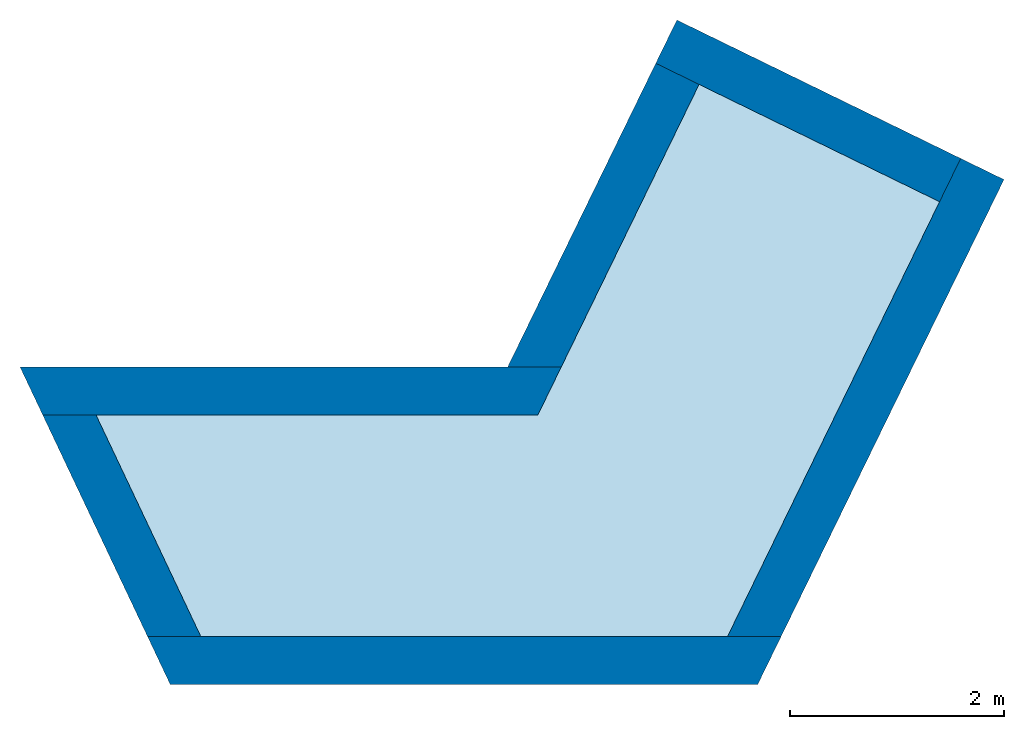
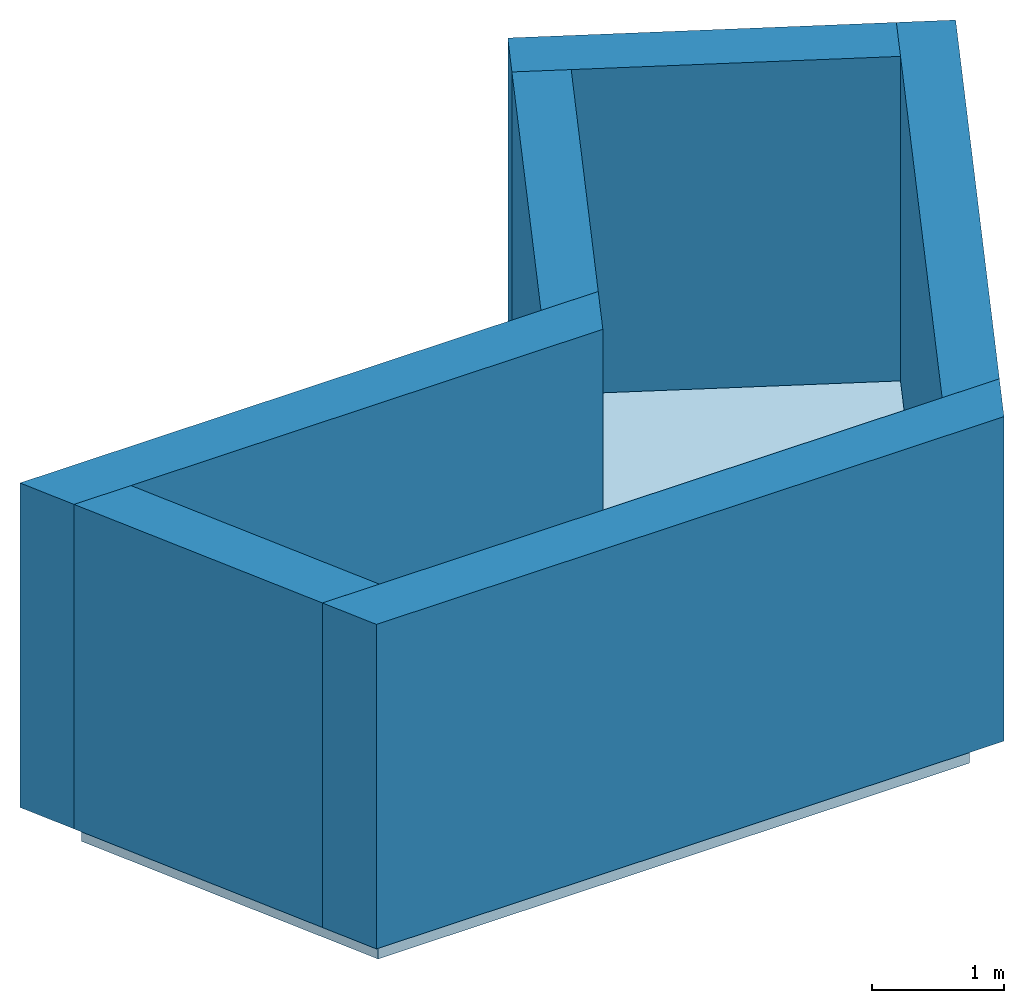
# One storey: 6 walls, 1 slab, 1 opening.
"""IFC4 building model written with IfcOpenShell, lengths in metres."""

import ifcopenshell
import ifcopenshell.guid

model = None  # the IFC model being written
_history = None  # IfcOwnerHistory: only IFC2X3 demands one
_inside = {}  # id of a spatial element -> (the spatial element, [elements in it])
_under = {}  # id of a project, library or spatial element -> (it, [spatial elements below it])
_declared = {}  # id of a project -> (the project, [libraries it declares])
_typed = {}  # id of a type object -> (the type object, [elements of that type])
_made_of = {}  # id of a material, layer set ... -> (it, [elements and type objects made of it])


def new_model(schema):
    """Start an empty IFC model of exactly this schema.

    Asked for "IFC4X3", IfcOpenShell would pick the latest addendum, in which some entities
    have other attributes; the version numbers below select the first issue.
    IFC2X3 requires an IfcOwnerHistory on every rooted entity: one is made here for all.
    """
    global model, _history
    if schema == "IFC4X3":
        model = ifcopenshell.file(schema_version=(4, 3, 0, 0))
    else:
        model = ifcopenshell.file(schema=schema)
    _inside.clear()
    _under.clear()
    _declared.clear()
    _typed.clear()
    _made_of.clear()
    _history = None
    if model.schema == "IFC2X3":
        org = make("IfcOrganization", Name="unknown")
        user = make(
            "IfcPersonAndOrganization",
            ThePerson=make("IfcPerson", FamilyName="unknown"),
            TheOrganization=org,
        )
        app = make(
            "IfcApplication",
            ApplicationDeveloper=org,
            Version="unknown",
            ApplicationFullName="unknown",
            ApplicationIdentifier="unknown",
        )
        _history = make(
            "IfcOwnerHistory",
            OwningUser=user,
            OwningApplication=app,
            ChangeAction="ADDED",
            CreationDate=0,
        )
    return model


def make(cls, **values):
    """One entity of the class cls with the attributes given. An attribute that is None is left unset."""
    return model.create_entity(
        cls, **{name: value for name, value in values.items() if value is not None}
    )


def entity(cls, *values):
    """Any entity or typed value of the class cls, its attributes in the order of the schema. None: left unset."""
    e = model.create_entity(cls)
    for i, value in enumerate(values):
        if value is not None:
            e[i] = value
    return e


def rooted(cls, **values):
    """An entity with a GlobalId (a new one), such as an element, a storey or a relation."""
    return make(cls, GlobalId=ifcopenshell.guid.new(), OwnerHistory=_history, **values)


def si_unit(unit_type, name, prefix=None):
    """IfcSIUnit, for example si_unit("LENGTHUNIT", "METRE", prefix="MILLI")."""
    return make("IfcSIUnit", UnitType=unit_type, Prefix=prefix, Name=name)


def converted_unit(unit_type, name, factor, base, dimensions=None, offset=None):
    """IfcConversionBasedUnit, such as the inch: factor (a typed value) times the base unit."""
    return make(
        "IfcConversionBasedUnit"
        if offset is None
        else "IfcConversionBasedUnitWithOffset",
        ConversionOffset=offset,
        Dimensions=None
        if dimensions is None
        else entity("IfcDimensionalExponents", *dimensions),
        UnitType=unit_type,
        Name=name,
        ConversionFactor=make(
            "IfcMeasureWithUnit", ValueComponent=factor, UnitComponent=base
        ),
    )


def derived_unit(unit_type, elements):
    """IfcDerivedUnit: a product of units, each with its exponent."""
    return make(
        "IfcDerivedUnit",
        Elements=[
            make("IfcDerivedUnitElement", Unit=unit, Exponent=power)
            for unit, power in elements
        ],
        UnitType=unit_type,
    )


def assignment(units):
    """IfcUnitAssignment: the units of a project."""
    return None if units is None else make("IfcUnitAssignment", Units=units)


def point(xyz):
    """IfcCartesianPoint."""
    return None if xyz is None else make("IfcCartesianPoint", Coordinates=xyz)


def direction(xyz):
    """IfcDirection."""
    return None if xyz is None else make("IfcDirection", DirectionRatios=xyz)


def frame(location, z_axis=None, x_axis=None):
    """IfcAxis2Placement3D, a coordinate frame: its origin and axes. An axis left out is left unset."""
    return make(
        "IfcAxis2Placement3D",
        Location=point(location),
        Axis=direction(z_axis),
        RefDirection=direction(x_axis),
    )


def origin():
    """The frame at (0, 0, 0) with its axes left unset."""
    return frame((0.0, 0.0, 0.0))


def place(relative_to, where):
    """IfcLocalPlacement: puts the frame where relative to a parent placement (None: the world)."""
    return make(
        "IfcLocalPlacement", PlacementRelTo=relative_to, RelativePlacement=where
    )


def context(
    kind, dimensions, precision=None, world=None, true_north=None, identifier=None
):
    """IfcGeometricRepresentationContext, for example the 3D "Model" context."""
    return make(
        "IfcGeometricRepresentationContext",
        ContextIdentifier=identifier,
        ContextType=kind,
        CoordinateSpaceDimension=dimensions,
        Precision=precision,
        WorldCoordinateSystem=world,
        TrueNorth=true_north,
    )


def subcontext(parent, identifier, kind, view, scale=None):
    """IfcGeometricRepresentationSubContext, for example "Body" below "Model"."""
    return make(
        "IfcGeometricRepresentationSubContext",
        ContextIdentifier=identifier,
        ContextType=kind,
        ParentContext=parent,
        TargetScale=scale,
        TargetView=view,
    )


def project(units=None, contexts=None):
    """IfcProject with its units and contexts."""
    return rooted(
        "IfcProject",
        Name="project",
        RepresentationContexts=contexts,
        UnitsInContext=assignment(units),
    )


def spatial(cls, under=None, at=None, **own):
    """A site, building, storey or space (cls), placed at a placement, below another one or the project."""
    s = rooted(cls, ObjectPlacement=at, **own)
    if under is not None:
        _under.setdefault(under.id(), (under, []))[1].append(s)
    return s


def point_list(points):
    """IfcCartesianPointList2D or 3D."""
    cls = (
        "IfcCartesianPointList2D" if len(points[0]) == 2 else "IfcCartesianPointList3D"
    )
    return make(cls, CoordList=points)


def indexed_curve(points, segments=None, self_intersect=None):
    """IfcIndexedPolyCurve: lines and arcs through numbered points (the first is 1)."""
    return make(
        "IfcIndexedPolyCurve",
        Points=point_list(points),
        Segments=segments,
        SelfIntersect=self_intersect,
    )


def outline(outer, holes=None, kind="AREA"):
    """IfcArbitraryClosedProfileDef: a profile drawn as a closed curve; with holes, ...WithVoids."""
    if holes is None:
        return make("IfcArbitraryClosedProfileDef", ProfileType=kind, OuterCurve=outer)
    return make(
        "IfcArbitraryProfileDefWithVoids",
        ProfileType=kind,
        OuterCurve=outer,
        InnerCurves=holes,
    )


def extrude(swept, where, along, depth):
    """IfcExtrudedAreaSolid: the profile swept, set in the frame where, extruded along a direction by depth."""
    return make(
        "IfcExtrudedAreaSolid",
        SweptArea=swept,
        Position=where,
        ExtrudedDirection=direction(along),
        Depth=depth,
    )


def polygons(points, faces, closed=None, point_numbers=None):
    """IfcPolygonalFaceSet: a face is its outer loop, then its inner loops; points numbered from 1."""
    made = []
    for loops in faces:
        if len(loops) == 1:
            made.append(make("IfcIndexedPolygonalFace", CoordIndex=loops[0]))
        else:
            made.append(
                make(
                    "IfcIndexedPolygonalFaceWithVoids",
                    CoordIndex=loops[0],
                    InnerCoordIndices=loops[1:],
                )
            )
    return make(
        "IfcPolygonalFaceSet",
        Coordinates=point_list(points),
        Closed=closed,
        Faces=made,
        PnIndex=point_numbers,
    )


def shape(context_of_items, identifier, shape_type, items):
    """IfcShapeRepresentation: the items that make up one representation, for example the "Body"."""
    return make(
        "IfcShapeRepresentation",
        ContextOfItems=context_of_items,
        RepresentationIdentifier=identifier,
        RepresentationType=shape_type,
        Items=items,
    )


def material(Name=None, Category=None):
    """IfcMaterial."""
    return make("IfcMaterial", Name=Name, Category=Category)


def layer(
    of_material, thickness, ventilated=None, Name=None, Category=None, Priority=None
):
    """IfcMaterialLayer: one layer of a wall or slab, of a material (None: an air gap)."""
    return make(
        "IfcMaterialLayer",
        Material=of_material,
        LayerThickness=thickness,
        IsVentilated=ventilated,
        Name=Name,
        Category=Category,
        Priority=Priority,
    )


def layer_set(layers, Name=None):
    """IfcMaterialLayerSet."""
    return make("IfcMaterialLayerSet", MaterialLayers=layers, LayerSetName=Name)


def made_of(thing, what):
    """Note that an element or type object is made of a material, layer set ...; save() writes the relation."""
    if what is not None:
        _made_of.setdefault(what.id(), (what, []))[1].append(thing)
    return thing


def type_object(cls, material=None, **own):
    """A type object (cls), such as IfcWallType, which elements share."""
    return made_of(rooted(cls, **own), material)


def element(
    cls,
    number,
    at=None,
    inside=None,
    cuts=None,
    type_object=None,
    material=None,
    context=None,
    identifier="Body",
    shape_type=None,
    held_by="IfcProductDefinitionShape",
    body=None,
    shapes=None,
    **own,
):
    """One element of the class cls, such as IfcWall. Its Tag is "e" and its number.

    at: its placement. inside: the storey or other place that contains it. cuts: it is an
    opening in that element (IfcRelVoidsElement). A single representation is given by context,
    identifier, shape_type and body (its items); several are given by shapes. held_by: the class
    of the entity that holds the representations. save() writes the other relations.
    """
    e = rooted(cls, Tag="e%d" % number, ObjectPlacement=at, **own)
    if body is not None:
        shapes = [shape(context, identifier, shape_type, body)]
    if shapes is not None:
        e.Representation = make(held_by, Representations=shapes)
    if inside is not None:
        _inside.setdefault(inside.id(), (inside, []))[1].append(e)
    if cuts is not None:
        rooted(
            "IfcRelVoidsElement", RelatingBuildingElement=cuts, RelatedOpeningElement=e
        )
    if type_object is not None:
        _typed.setdefault(type_object.id(), (type_object, []))[1].append(e)
    return made_of(e, material)


def aggregate(whole, parts):
    """IfcRelAggregates: a whole, such as a stair, and the parts it consists of."""
    return rooted("IfcRelAggregates", RelatingObject=whole, RelatedObjects=parts)


def save(model, path):
    """Write the relations noted so far, then the file.

    IfcRelAggregates (storeys below a building ...), IfcRelContainedInSpatialStructure (elements
    in a storey), IfcRelDefinesByType, IfcRelAssociatesMaterial and IfcRelDeclares: one each for
    every whole, place, type object, material and project.
    """
    for whole, parts in _under.values():
        aggregate(whole, parts)
    for where, things in _inside.values():
        rooted(
            "IfcRelContainedInSpatialStructure",
            RelatedElements=things,
            RelatingStructure=where,
        )
    for kind, things in _typed.values():
        rooted("IfcRelDefinesByType", RelatedObjects=things, RelatingType=kind)
    for what, things in _made_of.values():
        rooted("IfcRelAssociatesMaterial", RelatedObjects=things, RelatingMaterial=what)
    for by, libraries in _declared.values():
        rooted("IfcRelDeclares", RelatingContext=by, RelatedDefinitions=libraries)
    model.write(path)


model = new_model("IFC4")

# Units and contexts
model_context = context("Model", 3, precision=1e-05, world=origin(), true_north=direction((6.12303176911189e-17, 1.0)))
body_context = subcontext(model_context, "Body", "Model", "MODEL_VIEW")
ifc_project = project(units=[si_unit("LENGTHUNIT", "METRE"), si_unit("AREAUNIT", "SQUARE_METRE"), si_unit("VOLUMEUNIT", "CUBIC_METRE"), converted_unit("PLANEANGLEUNIT", "DEGREE", entity("IfcRatioMeasure", 0.0174532925199433), si_unit("PLANEANGLEUNIT", "RADIAN"), dimensions=[0, 0, 0, 0, 0, 0, 0]), si_unit("MASSUNIT", "GRAM", prefix="KILO"), derived_unit("MASSDENSITYUNIT", [(si_unit("MASSUNIT", "GRAM", prefix="KILO"), 1), (si_unit("LENGTHUNIT", "METRE"), -3)]), si_unit("TIMEUNIT", "SECOND"), si_unit("FREQUENCYUNIT", "HERTZ"), si_unit("THERMODYNAMICTEMPERATUREUNIT", "DEGREE_CELSIUS"), derived_unit("THERMALTRANSMITTANCEUNIT", [(si_unit("MASSUNIT", "GRAM", prefix="KILO"), 1), (si_unit("THERMODYNAMICTEMPERATUREUNIT", "KELVIN"), -1), (si_unit("TIMEUNIT", "SECOND"), -3)]), derived_unit("VOLUMETRICFLOWRATEUNIT", [(si_unit("LENGTHUNIT", "METRE"), 3), (si_unit("TIMEUNIT", "SECOND"), -1)]), si_unit("ELECTRICCURRENTUNIT", "AMPERE"), si_unit("ELECTRICVOLTAGEUNIT", "VOLT"), si_unit("POWERUNIT", "WATT"), si_unit("FORCEUNIT", "NEWTON", prefix="KILO"), si_unit("ILLUMINANCEUNIT", "LUX"), si_unit("LUMINOUSFLUXUNIT", "LUMEN"), si_unit("LUMINOUSINTENSITYUNIT", "CANDELA"), derived_unit("USERDEFINED", [(si_unit("MASSUNIT", "GRAM", prefix="KILO"), -1), (si_unit("LENGTHUNIT", "METRE"), -2), (si_unit("TIMEUNIT", "SECOND"), 3), (si_unit("LUMINOUSFLUXUNIT", "LUMEN"), 1)]), derived_unit("LINEARVELOCITYUNIT", [(si_unit("LENGTHUNIT", "METRE"), 1), (si_unit("TIMEUNIT", "SECOND"), -1)]), si_unit("PRESSUREUNIT", "PASCAL"), derived_unit("USERDEFINED", [(si_unit("LENGTHUNIT", "METRE"), -2), (si_unit("MASSUNIT", "GRAM", prefix="KILO"), 1), (si_unit("TIMEUNIT", "SECOND"), -2)])], contexts=[model_context])

# Site, building, storey
site_placement = place(None, origin())
site = spatial("IfcSite", under=ifc_project, at=site_placement, CompositionType="ELEMENT")
building_placement = place(site_placement, origin())
building = spatial("IfcBuilding", under=site, at=building_placement, Name="Revit Advanced Sample", CompositionType="ELEMENT")
storey_placement = place(building_placement, frame((0.0, 0.0, -3.0)))
storey = spatial("IfcBuildingStorey", under=building, at=storey_placement, Name="S1", CompositionType="ELEMENT", Elevation=-3.0)

# Slab
ifc_material_1 = material()
ifc_layer_1 = layer(ifc_material_1, 0.3)
ifc_layer_set_1 = layer_set([ifc_layer_1])
slab_type = type_object("IfcSlabType", PredefinedType="FLOOR", material=ifc_layer_set_1)
slab_placement = place(storey_placement, origin())
element("IfcSlab", 1, at=slab_placement, inside=storey, type_object=slab_type, PredefinedType="FLOOR", context=body_context, shape_type="SweptSolid", body=[
    extrude(outline(indexed_curve([(-1.98276627614818, -2.48532861992595), (3.19009775257676, -2.48532861992595), (4.35752517332644, -0.017981718067778), (0.0403738598966242, -0.0179817180677804), (-1.49936388769203, 3.13894850083789), (-4.10586662195961, 1.86767217514957), (-1.98276627614818, -2.48532861992595)], self_intersect=False)), frame((1.20259375117976, -2.87805110314894, 0.0), z_axis=(0.0, 0.0, -1.0), x_axis=(-1.0, 0.0, 0.0)), (0.0, 0.0, 1.0), 0.3),
])

# Wall, opening
ifc_material_2 = material()
ifc_layer_2 = layer(ifc_material_2, 0.05)
ifc_material_3 = material(Name="Isolation", Category="Isolation")
ifc_layer_3 = layer(ifc_material_3, 0.2, Name="Isolation", Category="Isolation")
ifc_material_4 = material()
ifc_layer_4 = layer(ifc_material_4, 0.2)
ifc_layer_set_2 = layer_set([ifc_layer_2, ifc_layer_3, ifc_layer_4])
wall_type = type_object("IfcWallType", PredefinedType="NOTDEFINED", material=ifc_layer_set_2)
wall_1_placement = place(storey_placement, frame((-2.35870602887282, -5.38837972307488, 0.0)))
wall_1 = element("IfcWall", 2, at=wall_1_placement, inside=storey, type_object=wall_type, material=ifc_layer_set_2, PredefinedType="NOTDEFINED", context=body_context, shape_type="Tessellation", body=[
    polygons([(0.212917907466403, -0.224999999999999, 0.0), (5.70028339417809, -0.225, 0.0), (5.70028339417809, -0.225, 3.0), (3.07207896611386, -0.225, 3.0), (2.11207896611386, -0.225, 3.0), (0.212917907466403, -0.224999999999999, 3.0), (1.34290594210879e-15, 0.225, 0.0), (-1.06779695141972e-17, 0.225, 3.0), (0.497829323483332, 0.225, 3.0), (2.11207896611386, 0.225, 3.0), (3.07207896611386, 0.225, 3.0), (5.41909218581889, 0.225, 3.0), (5.91976305903272, 0.225000000000001, 3.0), (5.91976305903272, 0.225000000000001, 0.0), (5.41909218581889, 0.225, 0.0), (0.497829323483333, 0.225, 0.0)], [[[6, 1, 2, 3, 4, 5]], [[14, 15, 16, 7, 8, 9, 10, 11, 12, 13]], [[2, 1, 7, 16, 15, 14]], [[4, 3, 13, 12, 11, 10, 9, 8, 6, 5]], [[3, 2, 14, 13]], [[8, 7, 1, 6]]], closed=True),
])
opening_placement = place(wall_1_placement, origin())
element("IfcOpeningElement", 3, at=opening_placement, cuts=wall_1, ObjectType="Opening", PredefinedType="OPENING", context=body_context, shape_type="SweptSolid", body=[
    extrude(outline(indexed_curve([(-1.065, -0.480000000000001), (1.065, -0.480000000000001), (1.065, 0.480000000000001), (-1.065, 0.480000000000001), (-1.065, -0.480000000000001)], self_intersect=False)), frame((2.59207896611386, -1.749, 4.065), z_axis=(0.0, 1.0, 0.0), x_axis=(0.0, 0.0, 1.0)), (0.0, 0.0, 1.0), 3.048),
])

# Walls
wall_2_placement = place(storey_placement, frame((3.26261481736338, -5.26201323110244, 0.0), z_axis=(0.0, 0.0, 1.0), x_axis=(0.438371146789078, 0.898794046299167, 0.0)))
element("IfcWall", 4, at=wall_2_placement, inside=storey, type_object=wall_type, material=ifc_layer_set_2, PredefinedType="NOTDEFINED", context=body_context, shape_type="SweptSolid", body=[
    extrude(outline(indexed_curve([(4.9681832611092, -0.224999999999999), (4.9681832611092, 0.225000000000001), (4.5181832611092, 0.225), (-1.35358391162299e-16, 0.225), (0.219479664854635, -0.225), (4.9681832611092, -0.224999999999999)], self_intersect=False)), origin(), (0.0, 0.0, 1.0), 3.0),
])
wall_3_placement = place(storey_placement, frame((1.50667342651964, -2.87103282121672, 0.0), z_axis=(0.0, 0.0, 1.0), x_axis=(-1.0, 0.0, 0.0)))
element("IfcWall", 5, at=wall_3_placement, inside=storey, type_object=wall_type, material=ifc_layer_set_2, PredefinedType="NOTDEFINED", context=body_context, shape_type="SweptSolid", body=[
    extrude(outline(indexed_curve([(5.05646442141617, -0.225), (4.84354651394976, 0.225), (4.34571719046643, 0.225), (0.219479664854638, 0.225), (-8.52641042571401e-17, -0.225), (0.500670873213835, -0.225), (5.05646442141617, -0.225)], self_intersect=False)), origin(), (0.0, 0.0, 1.0), 3.0),
])
wall_4_placement = place(storey_placement, frame((-3.13349013021188, -2.99980199084951, 0.0), z_axis=(0.0, 0.0, 1.0), x_axis=(0.427692579409759, -0.903924254303328, 0.0)))
element("IfcWall", 6, at=wall_4_placement, inside=storey, type_object=wall_type, material=ifc_layer_set_2, PredefinedType="NOTDEFINED", context=body_context, shape_type="SweptSolid", body=[
    extrude(outline(indexed_curve([(2.28707979901648, -0.225), (2.49999770648288, 0.225000000000001), (0.212917907466403, 0.225), (-8.45989944764369e-17, -0.225), (2.28707979901648, -0.225)], self_intersect=False)), origin(), (0.0, 0.0, 1.0), 3.0),
])
wall_5_placement = place(storey_placement, frame((5.13966084254927, -0.900234847484086, 0.0), z_axis=(0.0, 0.0, 1.0), x_axis=(-0.898794046299166, 0.438371146789079, 0.0)))
element("IfcWall", 7, at=wall_5_placement, inside=storey, type_object=wall_type, material=ifc_layer_set_2, PredefinedType="NOTDEFINED", context=body_context, shape_type="SweptSolid", body=[
    extrude(outline(indexed_curve([(2.95, 0.225), (-2.53796983429311e-16, 0.225), (2.53796983429311e-16, -0.225), (2.95, -0.225), (2.95, 0.225)], self_intersect=False)), origin(), (0.0, 0.0, 1.0), 3.0),
])
wall_6_placement = place(storey_placement, frame((2.5918135583565, 0.0920978670988417, 0.0), z_axis=(0.0, 0.0, 1.0), x_axis=(-0.438371146789079, -0.898794046299166, 0.0)))
element("IfcWall", 8, at=wall_6_placement, inside=storey, type_object=wall_type, material=ifc_layer_set_2, PredefinedType="NOTDEFINED", context=body_context, shape_type="SweptSolid", body=[
    extrude(outline(indexed_curve([(3.15618934952188, -0.225000000000001), (2.93670968466724, 0.225), (2.53796983429311e-16, 0.225), (5.07593966858622e-17, -0.225), (3.15618934952188, -0.225000000000001)], self_intersect=False)), origin(), (0.0, 0.0, 1.0), 3.0),
])

save(model, "model.ifc")
